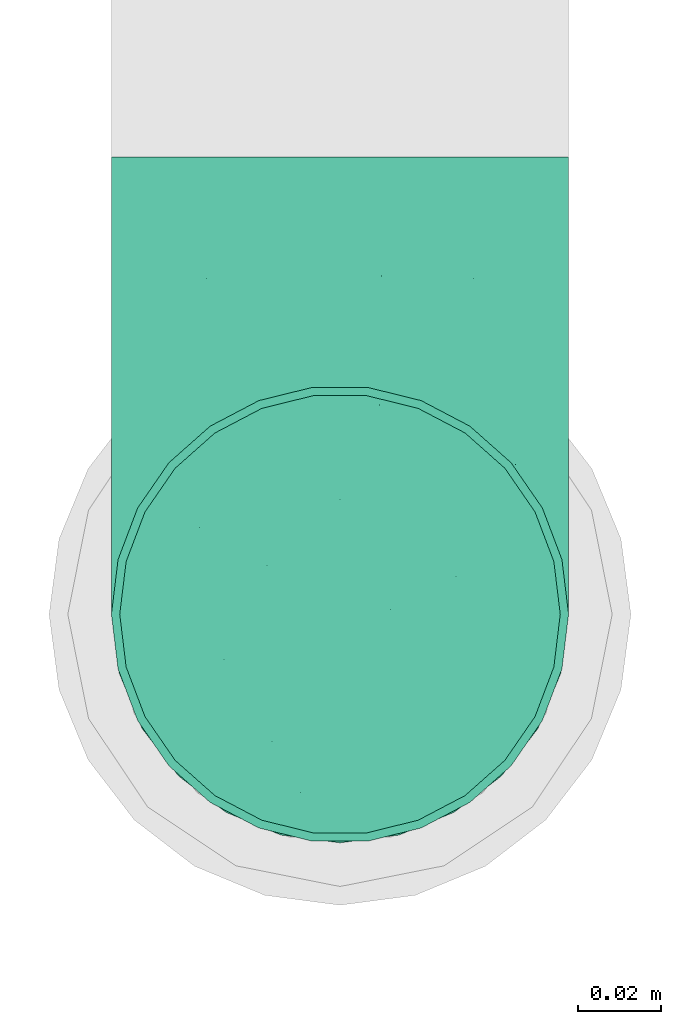
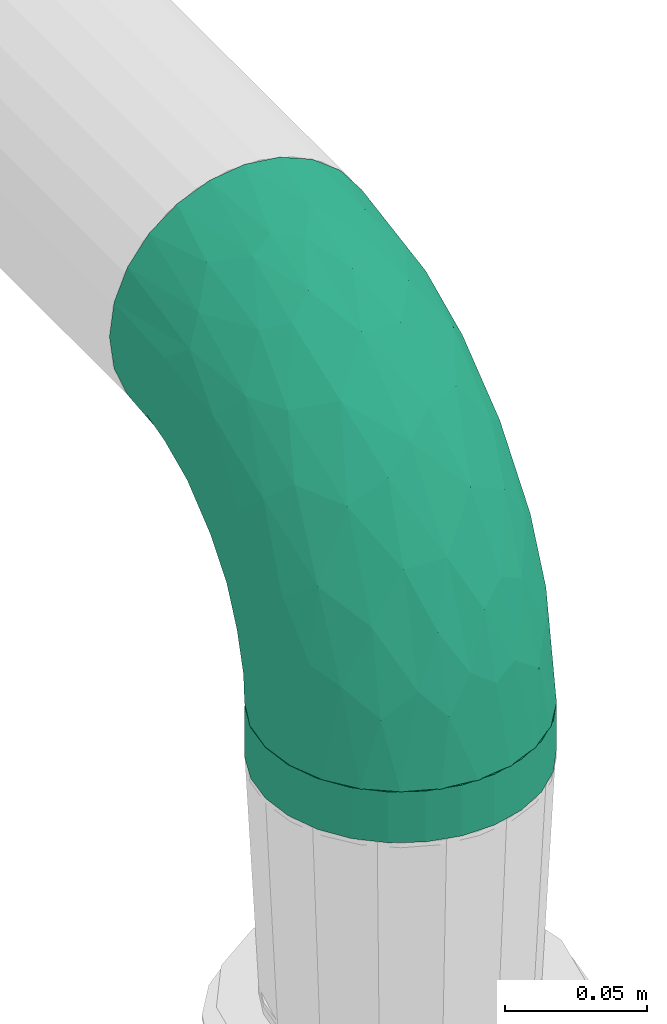
# One storey, part 84 of 123: 1 flow fitting, 1 flow segment.
"""IFC2X3 building model written with IfcOpenShell, lengths in millimetres."""

from ifc_helpers import new_model, entity, si_unit, converted_unit, derived_unit, direction, frame, origin_with_axes, origin_2d_with_axis, place, context, subcontext, project, spatial, hollow_circle, extrude, open_shell, surface_model, source, transform, mapped, material, layer, layer_set, layer_usage, type_object, element, save


model = new_model("IFC2X3")

# Units and contexts
model_context = context("Model", 3, precision=1e-05, world=origin_with_axes(), true_north=direction((0.0, 1.0)))
body_context = subcontext(model_context, "Body", "Model", "MODEL_VIEW")
ifc_project = project(units=[si_unit("AREAUNIT", "SQUARE_METRE"), si_unit("VOLUMEUNIT", "CUBIC_METRE", prefix="DECI"), si_unit("TIMEUNIT", "SECOND"), si_unit("THERMODYNAMICTEMPERATUREUNIT", "DEGREE_CELSIUS"), si_unit("PRESSUREUNIT", "PASCAL"), si_unit("MASSUNIT", "GRAM", prefix="KILO"), si_unit("LENGTHUNIT", "METRE", prefix="MILLI"), si_unit("POWERUNIT", "WATT"), si_unit("ELECTRICCURRENTUNIT", "AMPERE"), si_unit("ELECTRICVOLTAGEUNIT", "VOLT"), derived_unit("VOLUMETRICFLOWRATEUNIT", [(si_unit("VOLUMEUNIT", "CUBIC_METRE", prefix="DECI"), 1), (si_unit("TIMEUNIT", "SECOND"), -1)]), derived_unit("LINEARVELOCITYUNIT", [(si_unit("LENGTHUNIT", "METRE"), 1), (si_unit("TIMEUNIT", "SECOND"), -1)]), derived_unit("MASSDENSITYUNIT", [(si_unit("MASSUNIT", "GRAM", prefix="KILO"), 1), (si_unit("VOLUMEUNIT", "CUBIC_METRE"), -1)]), converted_unit("PLANEANGLEUNIT", "DEGREE", entity("IfcRatioMeasure", 0.01745), si_unit("PLANEANGLEUNIT", "RADIAN"), dimensions=[0, 0, 0, 0, 0, 0, 0])], contexts=[model_context])

# Site, building, storey
site_placement = place(None, origin_with_axes())
site = spatial("IfcSite", under=ifc_project, at=site_placement, CompositionType="ELEMENT")
building_placement = place(site_placement, origin_with_axes())
building = spatial("IfcBuilding", under=site, at=building_placement, Name="mc-building", CompositionType="ELEMENT")
storey_placement = place(building_placement, origin_with_axes())
storey = spatial("IfcBuildingStorey", under=building, at=storey_placement, Name="1. Korrus", CompositionType="ELEMENT", Elevation=0.0)

# Flow fitting
duct_fitting_type = type_object("IfcDuctFittingType", Name="BU", PredefinedType="BEND")
shared_shape_1 = source(origin_with_axes(), body_context, "Body", "SurfaceModel", [
    surface_model("IfcShellBasedSurfaceModel", [(-110.0, -38.89087, -38.89087), (-110.0, -55.0, 0.0), (-110.0, -27.5, -47.63139), (-110.0, -53.12592, -14.23505), (-110.0, -47.63139, -27.5), (-110.0, 47.63139, -27.5), (-110.0, 53.12592, 14.23505), (-110.0, 53.12592, -14.23505), (-110.0, -14.23505, -53.12592), (-110.0, 0.0, -55.0), (-110.0, 38.89087, -38.89087), (-110.0, 27.5, -47.63139), (-110.0, 14.23505, -53.12592), (-110.0, 55.0, 0.0), (-110.0, -53.12592, 14.23505), (-110.0, -47.63139, 27.5), (-110.0, -38.89087, 38.89087), (-110.0, 0.0, 55.0), (-110.0, -27.5, 47.63139), (-110.0, -14.23505, 53.12592), (-110.0, 38.89087, 38.89087), (-110.0, 47.63139, 27.5), (-110.0, 27.5, 47.63139), (-110.0, 14.23505, 53.12592), (0.0, -110.0, -55.0), (14.23505, -110.0, -53.12592), (-14.23505, -110.0, -53.12592), (-53.12592, -110.0, 14.23505), (-27.5, -110.0, -47.63139), (-47.63139, -110.0, -27.5), (-38.89087, -110.0, -38.89087), (55.0, -110.0, 0.0), (53.12592, -110.0, 14.23505), (38.89087, -110.0, -38.89087), (27.5, -110.0, -47.63139), (53.12592, -110.0, -14.23505), (47.63139, -110.0, -27.5), (-53.12592, -110.0, -14.23505), (-47.63139, -110.0, 27.5), (-38.89087, -110.0, 38.89087), (14.23505, -110.0, 53.12592), (-27.5, -110.0, 47.63139), (-14.23505, -110.0, 53.12592), (47.63139, -110.0, 27.5), (38.89087, -110.0, 38.89087), (27.5, -110.0, 47.63139), (0.0, -110.0, 55.0), (-55.0, -110.0, 0.0), (-60.44912, -32.56953, 51.94617), (-76.6405, -38.18013, 45.55988), (-64.21732, -48.68956, 43.63444), (-90.15553, -11.94394, 54.09138), (-76.00813, -5.38378, 55.0), (-70.18771, -18.55163, 54.03432), (-78.5998, -26.77405, 50.81338), (-93.27622, -45.77614, 33.48188), (-75.55424, -54.2118, 32.41257), (-96.12334, -22.13664, 50.81337), (-32.04182, -59.64019, 52.24446), (-18.36258, -70.48427, 54.04484), (-21.00813, -45.34362, 55.0), (-63.60674, -66.07878, 29.97482), (-74.66383, -63.08407, 19.92123), (-63.88653, -74.77858, 17.99134), (-93.11138, -56.59448, 10.50359), (-99.597, -52.72185, 18.52927), (-98.21577, -57.34403, 0.0), (-53.42855, -92.60092, 21.04759), (-88.54852, -54.8376, 21.04759), (-5.38378, -76.00813, 55.0), (-11.86161, -90.23965, 54.10313), (-56.64619, -93.12774, 10.22088), (-57.34403, -98.21577, 0.0), (-44.60838, -44.60838, 52.13415), (-45.34362, -21.00813, 55.0), (-92.68484, -35.46673, 43.63443), (-22.25266, -95.40765, 50.81337), (-27.23711, -77.39884, 50.81337), (-43.70931, -69.58671, 44.47149), (-35.97783, -90.61597, 43.63443), (-58.67786, -84.31125, 16.04456), (-57.2828, -79.3123, 24.9774), (-82.93277, -60.36161, 12.91784), (-49.88337, -54.51816, 47.224), (-74.57753, -66.83759, 9.55742), (-45.35812, -94.97281, 33.48188), (-59.18663, -88.95241, 0.0), (-51.517, -78.6292, 33.48188), (-65.14788, -80.03077, 0.0), (-56.45322, -62.06476, 39.63545), (-88.95241, -59.18663, 0.0), (-80.03077, -65.14788, 0.0), (-71.10913, -71.10913, 0.0), (-94.9309, -45.36788, -33.48188), (-93.11358, -56.60141, -10.46614), (-99.64997, -52.79499, -18.30015), (-79.99933, -46.56772, -37.92748), (-90.20425, -36.08686, -43.63443), (-45.34362, -21.00813, -55.0), (-72.75364, -19.68651, -53.60527), (-76.00813, -5.38378, -55.0), (-21.00813, -45.34362, -55.0), (-5.38378, -76.00813, -55.0), (-21.91957, -65.12078, -53.85897), (-35.41876, -92.89265, -43.63443), (-91.10309, -11.02766, -54.21832), (-45.77614, -93.27622, -33.48188), (-90.50474, -23.21022, -50.81337), (-70.92854, -33.31794, -49.51754), (-78.52933, -63.35627, -11.73997), (-24.91508, -84.05606, -50.81337), (-88.78941, -54.74452, -21.04759), (-63.49062, -67.59111, -28.46929), (-73.36422, -62.46673, -22.94182), (-69.59921, -57.34866, -33.48187), (-56.59448, -93.11138, -10.50359), (-54.10679, -75.85581, -32.31867), (-54.8376, -88.54852, -21.04759), (-57.75956, -31.09612, -52.80882), (-52.72185, -99.597, -18.52927), (-12.62913, -89.46304, -53.99097), (-34.46825, -66.46123, -50.04329), (-43.9837, -43.9837, -52.42279), (-65.78527, -72.58348, -17.68796), (-57.47001, -51.99467, -44.91465), (-70.34468, -43.65295, -44.21951), (-60.72547, -82.29174, -12.88567), (-42.34915, -74.24548, -43.63444), (-57.25194, -63.5016, -38.08211), (-80.95344, -53.56991, -29.32027), (-52.32891, -4.55257, -54.0482), (14.95561, -36.05775, -42.26543), (14.88266, -20.92917, -33.7947), (32.52942, -47.13398, -30.48571), (19.3559, -65.35825, -48.00507), (30.24048, -70.09027, -41.7461), (-28.49299, 30.5778, -16.4009), (-47.13398, 32.52942, -30.48571), (-70.35075, 46.44478, -19.5952), (-22.4954, -22.4954, -53.25347), (-4.55257, -52.32891, -54.0482), (-75.47368, 11.22546, -52.60718), (-81.32209, 51.5606, -9.98467), (-70.09027, 30.24048, -41.7461), (-80.81763, 41.84862, -32.14655), (-9.15831, 10.852, -27.8997), (-36.05774, 14.95561, -42.26543), (-65.35825, 19.3559, -48.00507), (3.94376, -43.9333, -50.53315), (11.22546, -75.47368, -52.60718), (-43.9333, 3.94376, -50.53315), (-13.39742, -13.39743, -48.13058), (50.20582, -74.51695, -9.9731), (41.8609, -47.82256, -9.92641), (49.37776, -67.29486, 0.0), (18.93131, -11.7156, -17.56239), (-1.23348, 12.25375, -12.18106), (-27.5, 32.89419, 0.0), (41.84862, -80.81763, -32.14655), (46.44478, -70.35075, -19.5952), (35.70604, -41.31408, -20.38235), (6.67262, 6.67262, 0.0), (32.89419, -27.5, 0.0), (-50.36265, 42.95545, -9.51562), (-67.29486, 49.37776, 0.0), (-5.47251, -5.47251, -39.92906), (-70.35075, 46.44478, 19.5952), (-74.51695, 50.20582, 9.9731), (-47.13398, 32.52942, 30.48571), (-41.31407, 35.70604, 20.38235), (-80.81763, 41.84862, 32.14655), (11.22546, -75.47368, 52.60718), (-4.55257, -52.32891, 54.0482), (-36.05774, 14.95561, 42.26543), (-65.35825, 19.3559, 48.00507), (-43.9333, 3.94376, 50.53315), (-70.09027, 30.24048, 41.7461), (-11.7156, 18.93131, 17.56239), (12.25375, -1.23348, 12.18106), (30.5778, -28.49299, 16.4009), (42.95545, -50.36265, 9.51562), (51.5606, -81.32209, 9.98467), (-52.32891, -4.55257, 54.0482), (-75.47368, 11.22546, 52.60718), (-13.39742, -13.39743, 48.13058), (-22.4954, -22.4954, 53.25347), (3.94376, -43.9333, 50.53315), (-20.92916, 14.88266, 33.79469), (10.852, -9.15831, 27.8997), (-47.82256, 41.8609, 9.92641), (32.52942, -47.13398, 30.48571), (46.44478, -70.35075, 19.5952), (41.84862, -80.81763, 32.14655), (14.95561, -36.05775, 42.26543), (19.3559, -65.35825, 48.00507), (30.24048, -70.09027, 41.7461), (-5.47251, -5.47251, 39.92906)], [open_shell([[[0, 1, 2]], [[3, 1, 4]], [[5, 6, 7]], [[8, 1, 9]], [[2, 1, 8]], [[4, 1, 0]], [[10, 9, 6]], [[9, 10, 11]], [[11, 12, 9]], [[6, 5, 10]], [[7, 6, 13]], [[14, 15, 9]], [[9, 15, 16]], [[17, 16, 18]], [[9, 16, 17]], [[19, 17, 18]], [[9, 20, 21]], [[6, 9, 21]], [[9, 22, 20]], [[23, 22, 9]], [[17, 23, 9]], [[9, 1, 14]], [[24, 25, 26]], [[26, 27, 28]], [[29, 30, 27]], [[28, 27, 30]], [[26, 31, 32]], [[33, 31, 34]], [[25, 34, 31]], [[35, 31, 36]], [[33, 36, 31]], [[31, 26, 25]], [[29, 27, 37]], [[38, 27, 26]], [[39, 38, 26]], [[40, 41, 26]], [[41, 39, 26]], [[40, 42, 41]], [[43, 44, 26]], [[43, 26, 32]], [[44, 45, 26]], [[26, 45, 40]], [[40, 46, 42]], [[47, 37, 27]], [[48, 49, 50]], [[51, 52, 17]], [[48, 53, 54]], [[49, 55, 56]], [[16, 15, 55]], [[18, 57, 19]], [[58, 59, 60]], [[61, 62, 63]], [[64, 65, 14]], [[53, 51, 54]], [[66, 64, 14]], [[27, 38, 67]], [[65, 68, 55]], [[68, 65, 64]], [[69, 59, 70]], [[71, 72, 27]], [[73, 60, 74]], [[55, 49, 75]], [[42, 70, 76]], [[51, 57, 54]], [[77, 78, 79]], [[42, 76, 41]], [[46, 70, 42]], [[55, 68, 56]], [[75, 18, 16]], [[77, 79, 76]], [[80, 67, 81]], [[68, 82, 62]], [[83, 78, 58]], [[82, 84, 62]], [[39, 79, 85]], [[71, 67, 80]], [[72, 71, 86]], [[67, 85, 87]], [[88, 80, 63]], [[39, 41, 79]], [[87, 79, 78]], [[55, 75, 16]], [[50, 89, 83]], [[38, 39, 85]], [[56, 68, 62]], [[61, 87, 89]], [[48, 50, 83]], [[18, 75, 57]], [[54, 75, 49]], [[38, 85, 67]], [[85, 79, 87]], [[56, 62, 61]], [[50, 56, 89]], [[87, 61, 81]], [[90, 64, 66]], [[14, 1, 66]], [[91, 92, 84]], [[82, 90, 91]], [[90, 82, 64]], [[62, 84, 63]], [[84, 82, 91]], [[64, 82, 68]], [[65, 15, 14]], [[15, 65, 55]], [[72, 47, 27]], [[86, 71, 80]], [[67, 71, 27]], [[88, 63, 92]], [[63, 80, 81]], [[63, 81, 61]], [[87, 81, 67]], [[41, 76, 79]], [[70, 59, 77]], [[76, 70, 77]], [[69, 70, 46]], [[77, 59, 58]], [[59, 69, 60]], [[77, 58, 78]], [[73, 58, 60]], [[19, 57, 51]], [[54, 57, 75]], [[19, 51, 17]], [[53, 52, 51]], [[53, 74, 52]], [[73, 74, 48]], [[53, 48, 74]], [[83, 73, 48]], [[73, 83, 58]], [[78, 83, 89]], [[78, 89, 87]], [[61, 89, 56]], [[54, 49, 48]], [[50, 49, 56]], [[88, 86, 80]], [[63, 84, 92]], [[93, 4, 0]], [[66, 94, 90]], [[95, 94, 3]], [[96, 93, 97]], [[98, 99, 100]], [[0, 2, 97]], [[101, 102, 103]], [[104, 28, 30]], [[9, 105, 8]], [[30, 106, 104]], [[107, 105, 99]], [[97, 107, 108]], [[94, 109, 90]], [[2, 8, 107]], [[94, 66, 3]], [[110, 26, 28]], [[94, 111, 109]], [[112, 113, 114]], [[72, 115, 37]], [[116, 106, 117]], [[98, 118, 99]], [[119, 115, 117]], [[115, 119, 37]], [[110, 120, 26]], [[103, 110, 121]], [[117, 106, 119]], [[120, 110, 103]], [[98, 101, 122]], [[117, 123, 116]], [[108, 124, 125]], [[126, 117, 115]], [[30, 29, 106]], [[120, 102, 24]], [[110, 104, 127]], [[97, 125, 96]], [[118, 122, 124]], [[124, 127, 128]], [[93, 0, 97]], [[86, 126, 115]], [[127, 106, 116]], [[129, 113, 111]], [[4, 93, 95]], [[114, 129, 96]], [[28, 104, 110]], [[127, 104, 106]], [[2, 107, 97]], [[108, 107, 99]], [[118, 108, 99]], [[100, 99, 105]], [[128, 112, 114]], [[127, 124, 121]], [[66, 1, 3]], [[91, 90, 109]], [[95, 111, 94]], [[109, 123, 92]], [[114, 113, 129]], [[111, 95, 93]], [[95, 3, 4]], [[86, 115, 72]], [[37, 47, 72]], [[88, 92, 123]], [[123, 117, 126]], [[126, 88, 123]], [[88, 126, 86]], [[119, 29, 37]], [[29, 119, 106]], [[111, 93, 129]], [[124, 114, 125]], [[100, 105, 9]], [[8, 105, 107]], [[108, 118, 124]], [[122, 118, 98]], [[96, 129, 93]], [[109, 111, 113]], [[113, 123, 109]], [[116, 123, 112]], [[113, 112, 123]], [[116, 112, 128]], [[116, 128, 127]], [[124, 128, 114]], [[103, 122, 101]], [[127, 121, 110]], [[121, 122, 103]], [[122, 121, 124]], [[26, 120, 24]], [[102, 120, 103]], [[108, 125, 97]], [[109, 92, 91]], [[96, 125, 114]], [[100, 130, 98]], [[131, 132, 133]], [[134, 135, 34]], [[136, 137, 138]], [[101, 139, 140]], [[9, 141, 100]], [[138, 7, 142]], [[137, 143, 144]], [[142, 7, 13]], [[145, 146, 137]], [[146, 147, 143]], [[5, 138, 144]], [[7, 138, 5]], [[5, 144, 10]], [[140, 148, 149]], [[143, 11, 10]], [[147, 12, 11]], [[100, 141, 130]], [[98, 139, 101]], [[148, 134, 149]], [[139, 150, 151]], [[152, 153, 154]], [[150, 139, 130]], [[25, 24, 149]], [[141, 12, 147]], [[132, 145, 155]], [[156, 136, 157]], [[158, 33, 135]], [[148, 139, 151]], [[36, 33, 158]], [[34, 135, 33]], [[159, 160, 153]], [[160, 159, 133]], [[137, 146, 143]], [[152, 154, 31]], [[137, 136, 145]], [[161, 162, 155]], [[133, 159, 158]], [[134, 148, 131]], [[163, 164, 157]], [[163, 142, 164]], [[102, 101, 140]], [[162, 154, 153]], [[159, 35, 36]], [[155, 156, 161]], [[131, 165, 132]], [[155, 145, 156]], [[98, 130, 139]], [[150, 130, 141]], [[147, 150, 141]], [[9, 12, 141]], [[149, 24, 102]], [[148, 140, 139]], [[140, 149, 102]], [[34, 25, 134]], [[146, 151, 150]], [[143, 147, 11]], [[147, 146, 150]], [[145, 165, 146]], [[25, 149, 134]], [[135, 134, 131]], [[135, 131, 133]], [[151, 165, 131]], [[148, 151, 131]], [[165, 151, 146]], [[160, 133, 132]], [[132, 165, 145]], [[36, 158, 159]], [[133, 158, 135]], [[10, 144, 143]], [[137, 144, 138]], [[162, 153, 155]], [[159, 153, 152]], [[160, 155, 153]], [[155, 160, 132]], [[152, 35, 159]], [[35, 152, 31]], [[136, 138, 163]], [[164, 142, 13]], [[142, 163, 138]], [[136, 163, 157]], [[161, 156, 157]], [[136, 156, 145]], [[166, 6, 21]], [[167, 164, 13]], [[166, 168, 169]], [[170, 168, 166]], [[69, 171, 172]], [[173, 174, 175]], [[174, 176, 22]], [[161, 157, 177]], [[170, 20, 176]], [[21, 20, 170]], [[178, 179, 162]], [[180, 181, 154]], [[182, 175, 183]], [[183, 23, 17]], [[184, 185, 186]], [[74, 185, 182]], [[52, 74, 182]], [[187, 188, 177]], [[166, 169, 189]], [[190, 179, 188]], [[22, 176, 20]], [[180, 154, 162]], [[32, 191, 43]], [[192, 44, 43]], [[43, 191, 192]], [[32, 31, 181]], [[193, 194, 195]], [[194, 40, 45]], [[190, 193, 195]], [[45, 44, 195]], [[69, 46, 171]], [[74, 60, 185]], [[157, 164, 189]], [[167, 189, 164]], [[172, 60, 69]], [[185, 172, 186]], [[173, 187, 168]], [[191, 32, 181]], [[190, 195, 192]], [[179, 190, 191]], [[175, 174, 183]], [[171, 40, 194]], [[188, 193, 190]], [[175, 185, 184]], [[177, 178, 161]], [[173, 196, 187]], [[177, 188, 178]], [[60, 172, 185]], [[186, 172, 171]], [[194, 186, 171]], [[46, 40, 171]], [[183, 17, 52]], [[175, 182, 185]], [[182, 183, 52]], [[22, 23, 174]], [[193, 184, 186]], [[195, 194, 45]], [[194, 193, 186]], [[188, 196, 193]], [[23, 183, 174]], [[176, 174, 173]], [[176, 173, 168]], [[184, 196, 173]], [[175, 184, 173]], [[196, 184, 193]], [[169, 168, 187]], [[187, 196, 188]], [[21, 170, 166]], [[168, 170, 176]], [[44, 192, 195]], [[190, 192, 191]], [[157, 189, 177]], [[166, 189, 167]], [[169, 177, 189]], [[177, 169, 187]], [[167, 6, 166]], [[6, 167, 13]], [[179, 191, 180]], [[154, 181, 31]], [[181, 180, 191]], [[179, 180, 162]], [[161, 178, 162]], [[179, 178, 188]]])]),
])
flow_fitting_placement = place(storey_placement, frame((19046.0369, 8254.17592, 2435.0), z_axis=(-1.0, 0.0, 0.0), x_axis=(0.0, -1.0, 0.0)))
element("IfcFlowFitting", 1, at=flow_fitting_placement, inside=storey, type_object=duct_fitting_type, Name="BU", context=body_context, shape_type="MappedRepresentation", body=[
    mapped(shared_shape_1, transform((0.0, 0.0, 0.0), scale=1.0)),
])

# Flow segment
ifc_material = material(Name="FZ1")
ifc_layer = layer(ifc_material, 0.0)
ifc_layer_set = layer_set([ifc_layer], Name="FZ1")
ifc_layer_usage = layer_usage(ifc_layer_set, "AXIS1", "POSITIVE", 0.0)
duct_segment_type = type_object("IfcDuctSegmentType", PredefinedType="RIGIDSEGMENT")
shared_shape_2 = source(origin_with_axes(), body_context, "Body", "SweptSolid", [
    extrude(hollow_circle(Radius=55.0, WallThickness=2.0, at=origin_2d_with_axis()), frame((0.0, 0.0, 0.0), z_axis=(1.0, 0.0, 0.0), x_axis=(0.0, 1.0, 0.0)), (0.0, 0.0, 1.0), 21.9),
])
flow_segment_placement = place(storey_placement, frame((19046.0369, 8254.17592, 2325.0), z_axis=(0.0, 1.0, 0.0), x_axis=(0.0, 0.0, -1.0)))
element("IfcFlowSegment", 2, at=flow_segment_placement, inside=storey, type_object=duct_segment_type, material=ifc_layer_usage, context=body_context, shape_type="MappedRepresentation", body=[
    mapped(shared_shape_2, transform((0.0, 0.0, 0.0), scale=1.0)),
])

save(model, "model.ifc")
